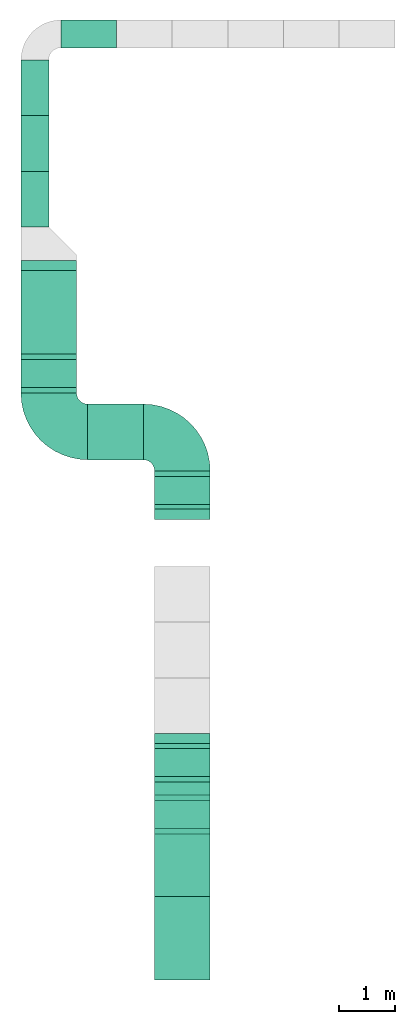
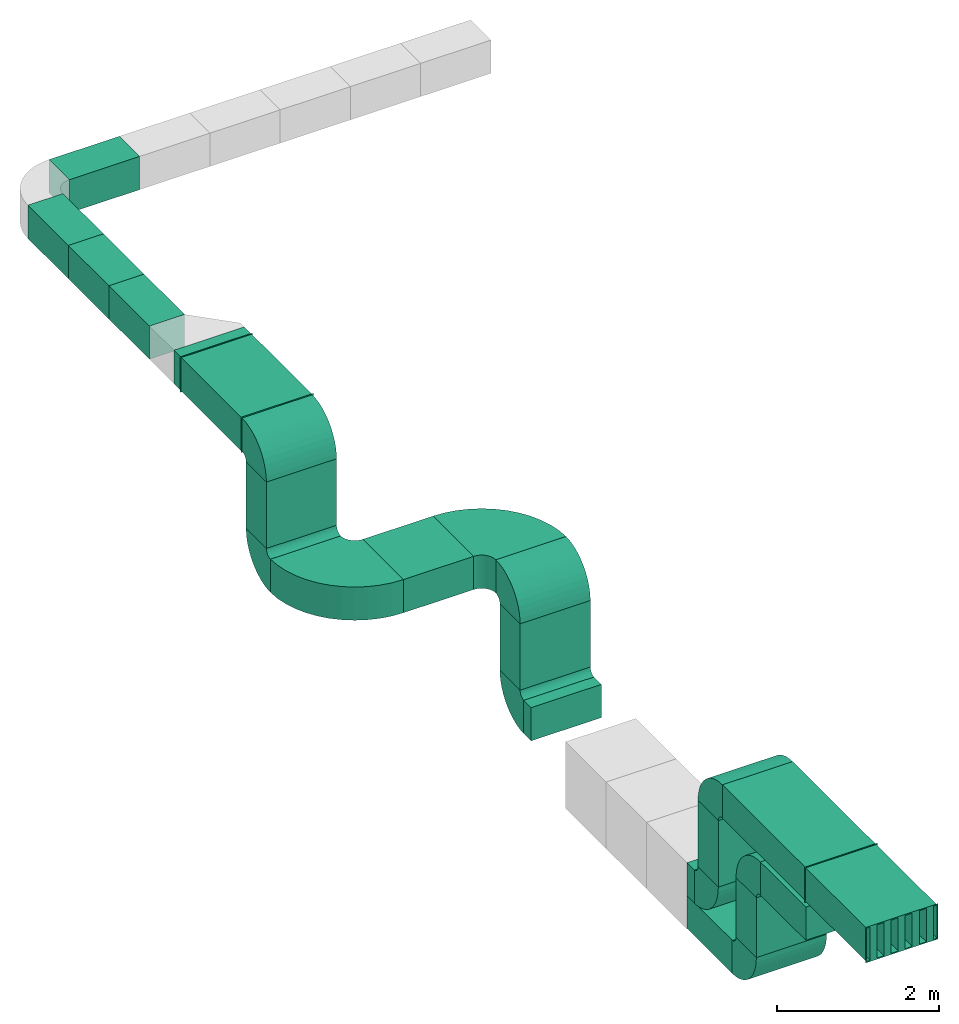
# One storey, part 1 of 3: 15 duct segments, 10 duct fittings, 2 duct silencers.
"""IFC4X3_ADD2 building model written with IfcOpenShell, lengths in millimetres."""

from ifc_helpers import new_model, entity, si_unit, converted_unit, frame, origin_with_axes, origin_2d_with_axis, place, context, subcontext, project, spatial, indexed_curve, rectangle, outline, extrude, polygons, source, transform, mapped, material, material_profile, profile_set, profile_usage, type_object, type_shapes, element, save


model = new_model("IFC4X3_ADD2")

# Units and contexts
model_context = context("Model", 3, precision=1e-05, world=origin_with_axes())
plan_context = context("Plan", 2, precision=1e-05, world=origin_2d_with_axis())
body_context = subcontext(model_context, "Body", "Model", "MODEL_VIEW")
ifc_project = project(units=[si_unit("VOLUMEUNIT", "CUBIC_METRE"), si_unit("LENGTHUNIT", "METRE", prefix="MILLI"), converted_unit("PLANEANGLEUNIT", "degree", entity("IfcReal", 0.0174532925199433), si_unit("PLANEANGLEUNIT", "RADIAN"), dimensions=[0, 0, 0, 0, 0, 0, 0]), si_unit("AREAUNIT", "SQUARE_METRE")], contexts=[model_context, plan_context])

# Site, building, storey
site_placement = place(None, origin_with_axes())
site = spatial("IfcSite", under=ifc_project, at=site_placement)
building_placement = place(site_placement, origin_with_axes())
building = spatial("IfcBuilding", under=site, at=building_placement, Name="Building")
storey_placement = place(building_placement, origin_with_axes())
storey = spatial("IfcBuildingStorey", under=building, at=storey_placement, Name="Storey")

# Duct silencers
duct_silencer_type = type_object("IfcDuctSilencerType", Name="Duct", PredefinedType="RECTANGULAR")
shared_shape_1 = source(origin_with_axes(), body_context, "Body", "Tessellation", [
    polygons([(350.0, -750.0, -249.999984741211), (450.000030517578, -750.0, -249.999984741211), (350.0, 750.0, -249.999984741211), (450.000030517578, 750.0, -249.999984741211), (350.0, -750.0, 249.999984741211), (450.000030517578, -750.0, 249.999984741211), (350.0, 750.0, 249.999984741211), (450.000030517578, 750.0, 249.999984741211), (150.000015258789, -750.0, -249.999984741211), (250.000015258789, -750.0, -249.999984741211), (150.000015258789, 750.0, -249.999984741211), (250.000015258789, 750.0, -249.999984741211), (150.000015258789, -750.0, 249.999984741211), (250.000015258789, -750.0, 249.999984741211), (150.000015258789, 750.0, 249.999984741211), (250.000015258789, 750.0, 249.999984741211), (-50.0, -750.0, -249.999984741211), (50.0, -750.0, -249.999984741211), (-50.0, 750.0, -249.999984741211), (50.0, 750.0, -249.999984741211), (-50.0, -750.0, 249.999984741211), (50.0, -750.0, 249.999984741211), (-50.0, 750.0, 249.999984741211), (50.0, 750.0, 249.999984741211), (-249.999969482422, -750.0, -249.999984741211), (-149.999984741211, -750.0, -249.999984741211), (-249.999969482422, 750.0, -249.999984741211), (-149.999984741211, 750.0, -249.999984741211), (-249.999969482422, -750.0, 249.999984741211), (-149.999984741211, -750.0, 249.999984741211), (-249.999969482422, 750.0, 249.999984741211), (-149.999984741211, 750.0, 249.999984741211), (-449.999969482422, -750.0, -249.999984741211), (-349.999938964844, -750.0, -249.999984741211), (-449.999969482422, 750.0, -249.999984741211), (-349.999938964844, 750.0, -249.999984741211), (-449.999969482422, -750.0, 249.999984741211), (-349.999938964844, -750.0, 249.999984741211), (-449.999969482422, 750.0, 249.999984741211), (-349.999938964844, 750.0, 249.999984741211), (-501.999938964844, -750.0, -251.999984741211), (-499.999969482422, -750.0, -249.999984741211), (-499.999969482422, -750.0, 0.0), (-499.999969482422, -750.0, 249.999984741211), (-501.999938964844, -750.0, 251.999984741211), (-499.999969482422, 0.0, -249.999984741211), (-501.999938964844, 750.0, -251.999984741211), (-499.999969482422, 750.0, -249.999984741211), (-499.999969482422, 0.0, 0.0), (-499.999969482422, 0.0, 249.999984741211), (-499.999969482422, 750.0, 0.0), (-499.999969482422, 750.0, 249.999984741211), (-501.999938964844, 750.0, 251.999984741211), (501.999938964844, -750.0, -251.999984741211), (499.999969482422, -750.0, -249.999984741211), (499.999969482422, -750.0, 0.0), (499.999969482422, -750.0, 249.999984741211), (501.999938964844, -750.0, 251.999984741211), (499.999969482422, 0.0, -249.999984741211), (501.999938964844, 750.0, -251.999984741211), (499.999969482422, 750.0, -249.999984741211), (499.999969482422, 0.0, 0.0), (499.999969482422, 0.0, 249.999984741211), (499.999969482422, 750.0, 0.0), (499.999969482422, 750.0, 249.999984741211), (501.999938964844, 750.0, 251.999984741211), (-516.999938964844, -750.0, -266.999969482422), (516.999938964844, -750.0, -266.999969482422), (-516.999938964844, -748.000061035156, -266.999969482422), (516.999938964844, -748.000061035156, -266.999969482422), (-516.999938964844, -750.0, 266.999969482422), (516.999938964844, -750.0, 266.999969482422), (-516.999938964844, -748.000061035156, 266.999969482422), (516.999938964844, -748.000061035156, 266.999969482422), (-501.999938964844, -749.999938964844, 251.999969482422), (-501.999938964844, -748.000122070312, 251.999984741211), (501.999938964844, -750.000061035156, 251.999984741211), (501.999938964844, -748.000122070312, 251.999984741211), (501.999938964844, -750.000061035156, -251.999984741211), (501.999938964844, -748.000122070312, -251.999984741211), (-501.999938964844, -749.999938964844, -251.999969482422), (-501.999938964844, -748.000122070312, -251.999984741211), (-516.999938964844, 748.000061035156, -266.999969482422), (516.999938964844, 748.000061035156, -266.999969482422), (-516.999938964844, 750.0, -266.999969482422), (516.999938964844, 750.0, -266.999969482422), (-516.999938964844, 748.000061035156, 266.999969482422), (516.999938964844, 748.000061035156, 266.999969482422), (-516.999938964844, 750.0, 266.999969482422), (516.999938964844, 750.0, 266.999969482422), (-501.999938964844, 748.000122070312, 251.999969482422), (-501.999938964844, 749.999938964844, 251.999984741211), (501.999938964844, 748.0, 251.999984741211), (501.999938964844, 749.999938964844, 251.999984741211), (501.999938964844, 748.0, -251.999984741211), (501.999938964844, 749.999938964844, -251.999984741211), (-501.999938964844, 748.000122070312, -251.999969482422), (-501.999938964844, 749.999938964844, -251.999984741211)], [[[1, 3, 4, 2]], [[1, 2, 6, 5]], [[5, 6, 8, 7]], [[3, 7, 8, 4]], [[1, 5, 7, 3]], [[2, 4, 8, 6]], [[9, 11, 12, 10]], [[9, 10, 14, 13]], [[13, 14, 16, 15]], [[11, 15, 16, 12]], [[9, 13, 15, 11]], [[10, 12, 16, 14]], [[17, 19, 20, 18]], [[17, 18, 22, 21]], [[21, 22, 24, 23]], [[19, 23, 24, 20]], [[17, 21, 23, 19]], [[18, 20, 24, 22]], [[25, 27, 28, 26]], [[25, 26, 30, 29]], [[29, 30, 32, 31]], [[27, 31, 32, 28]], [[25, 29, 31, 27]], [[26, 28, 32, 30]], [[33, 35, 36, 34]], [[33, 34, 38, 37]], [[37, 38, 40, 39]], [[35, 39, 40, 36]], [[33, 37, 39, 35]], [[34, 36, 40, 38]], [[41, 47, 60, 54]], [[45, 41, 43]], [[54, 58, 57, 56]], [[66, 53, 45, 58]], [[51, 48, 61, 64, 60, 47, 53, 66, 65, 52]], [[60, 64, 65, 66]], [[41, 45, 53, 47]], [[66, 58, 54, 60]], [[59, 46, 42, 55]], [[61, 48, 46, 59]], [[44, 50, 63, 57]], [[50, 52, 65, 63]], [[49, 43, 42, 46]], [[51, 49, 46, 48]], [[50, 44, 43, 49]], [[52, 50, 49, 51]], [[55, 56, 62, 59]], [[59, 62, 64, 61]], [[56, 57, 63, 62]], [[62, 63, 65, 64]], [[67, 69, 70, 68]], [[75, 72, 71]], [[71, 72, 74, 73]], [[69, 82, 70]], [[67, 71, 73, 69]], [[68, 70, 74, 72]], [[79, 67, 68]], [[77, 78, 80, 79]], [[79, 80, 82, 81]], [[75, 76, 78, 77]], [[81, 82, 76, 75]], [[78, 73, 74]], [[83, 85, 86, 84]], [[91, 88, 87]], [[87, 88, 90, 89]], [[85, 98, 86]], [[83, 87, 89, 85]], [[84, 86, 90, 88]], [[95, 83, 84]], [[93, 94, 96, 95]], [[95, 96, 98, 97]], [[91, 92, 94, 93]], [[97, 98, 92, 91]], [[94, 89, 90]], [[54, 56, 55]], [[54, 55, 42]], [[57, 58, 45]], [[44, 57, 45]], [[41, 54, 42]], [[43, 44, 45]], [[41, 42, 43]], [[71, 67, 81]], [[75, 77, 72]], [[71, 81, 75]], [[69, 73, 76]], [[82, 80, 70]], [[69, 76, 82]], [[68, 72, 77]], [[79, 81, 67]], [[68, 77, 79]], [[74, 70, 80]], [[78, 76, 73]], [[74, 80, 78]], [[87, 83, 97]], [[91, 93, 88]], [[87, 97, 91]], [[85, 89, 92]], [[98, 96, 86]], [[85, 92, 98]], [[84, 88, 93]], [[95, 97, 83]], [[84, 93, 95]], [[90, 86, 96]], [[94, 92, 89]], [[90, 96, 94]]], closed=True),
])
type_shapes(duct_silencer_type, [shared_shape_1])
for number, where, z_axis, x_axis in (
    (1, (-133.152961730957, 957.489967346191, 4035.20965576172), (0.0, 0.0, 1.0), (1.0, 0.0, 0.0)),
    (2, (2264.84680175781, -10289.3934249878, 2335.26062965393), (0.0, 0.0, 1.0), (1.0, 0.0, 0.0)),
):
    element("IfcDuctSilencer", number, at=place(storey_placement, frame(where, z_axis=z_axis, x_axis=x_axis)), inside=storey, type_object=duct_silencer_type, context=body_context, shape_type="MappedRepresentation", body=[
        mapped(shared_shape_1, transform((0.0, 0.0, 0.0), x_axis=(1.0, 0.0, 0.0), y_axis=(0.0, 1.0, 0.0), z_axis=(0.0, 0.0, 1.0), scale=1.0)),
    ])

# Duct segments
ifc_material = material()
ifc_material_profile_1 = material_profile(ifc_material, outline(indexed_curve([(-249.999954223633, 249.999954223633), (249.999954223633, 249.999954223633), (249.999954223633, -249.999954223633), (-249.999954223633, -249.999954223633), (-249.999954223633, 249.999954223633)])))
ifc_profile_set_1 = profile_set([ifc_material_profile_1])
ifc_profile_usage_1 = profile_usage(ifc_profile_set_1, cardinal=5)
duct_segment_type_1 = type_object("IfcDuctSegmentType", Name="Duct500x500", PredefinedType="RIGIDSEGMENT", material=ifc_profile_set_1)
duct_segment_1_placement = place(storey_placement, frame((-383.152931928635, 2490.50331115723, 4035.20965576172), z_axis=(-8.74227765734753e-08, 0.999999999999993, 7.54979012640428e-08), x_axis=(-0.999999999999992, -8.74227765734752e-08, 8.74227836789026e-08)))
element("IfcDuctSegment", 3, at=duct_segment_1_placement, inside=storey, type_object=duct_segment_type_1, material=ifc_profile_usage_1, Name="DuctSegment", context=body_context, shape_type="SweptSolid", body=[
    extrude(outline(indexed_curve([(-249.999954223633, 249.999954223633), (249.999954223633, 249.999954223633), (249.999954223633, -249.999954223633), (-249.999954223633, -249.999954223633), (-249.999954223633, 249.999954223633)])), origin_with_axes(), (0.0, 0.0, 1.0), 1000.00000000001),
])
ifc_profile_usage_2 = profile_usage(ifc_profile_set_1, cardinal=5)
duct_segment_2_placement = place(storey_placement, frame((1084.83171463013, 5958.48846435547, 4035.2087020874), z_axis=(-0.999999999999997, -1.19248735330757e-08, 7.54979012640431e-08), x_axis=(1.1924880638503e-08, -0.999999999999996, 8.74227765734755e-08)))
element("IfcDuctSegment", 4, at=duct_segment_2_placement, inside=storey, type_object=duct_segment_type_1, material=ifc_profile_usage_2, Name="DuctSegment", context=body_context, shape_type="SweptSolid", body=[
    extrude(outline(indexed_curve([(-249.999954223633, 249.999954223633), (249.999954223633, 249.999954223633), (249.999954223633, -249.999954223633), (-249.999954223633, -249.999954223633), (-249.999954223633, 249.999954223633)])), origin_with_axes(), (0.0, 0.0, 1.0), 1000.00000000001),
])
ifc_profile_usage_3 = profile_usage(ifc_profile_set_1, cardinal=5)
duct_segment_3_placement = place(storey_placement, frame((-383.152931928635, 3490.50331115723, 4035.20965576172), z_axis=(-8.74227765734753e-08, 0.999999999999993, 7.54979012640428e-08), x_axis=(-0.999999999999992, -8.74227765734752e-08, 8.74227836789026e-08)))
element("IfcDuctSegment", 5, at=duct_segment_3_placement, inside=storey, type_object=duct_segment_type_1, material=ifc_profile_usage_3, Name="DuctSegment", context=body_context, shape_type="SweptSolid", body=[
    extrude(outline(indexed_curve([(-249.999954223633, 249.999954223633), (249.999954223633, 249.999954223633), (249.999954223633, -249.999954223633), (-249.999954223633, -249.999954223633), (-249.999954223633, 249.999954223633)])), origin_with_axes(), (0.0, 0.0, 1.0), 1000.00000000001),
])
ifc_profile_usage_4 = profile_usage(ifc_profile_set_1, cardinal=5)
duct_segment_4_placement = place(storey_placement, frame((-383.152931928635, 4490.50331115723, 4035.20965576172), z_axis=(-8.74227765734753e-08, 0.999999999999993, 7.54979012640428e-08), x_axis=(-0.999999999999992, -8.74227765734752e-08, 8.74227836789026e-08)))
element("IfcDuctSegment", 6, at=duct_segment_4_placement, inside=storey, type_object=duct_segment_type_1, material=ifc_profile_usage_4, Name="DuctSegment", context=body_context, shape_type="SweptSolid", body=[
    extrude(outline(indexed_curve([(-249.999954223633, 249.999954223633), (249.999954223633, 249.999954223633), (249.999954223633, -249.999954223633), (-249.999954223633, -249.999954223633), (-249.999954223633, 249.999954223633)])), origin_with_axes(), (0.0, 0.0, 1.0), 1000.00000000001),
])
ifc_material_profile_2 = material_profile(ifc_material, rectangle(XDim=1000.0, YDim=500.0))
ifc_profile_set_2 = profile_set([ifc_material_profile_2], Name="duct1000x500")
ifc_profile_usage_5 = profile_usage(ifc_profile_set_2, cardinal=5)
duct_segment_type_2 = type_object("IfcDuctSegmentType", Name="Duct1000x500", PredefinedType="RIGIDSEGMENT", material=ifc_profile_set_2)
duct_segment_5_placement = place(storey_placement, frame((-133.152961730957, 1707.48996734619, 4035.20965576172), z_axis=(-8.74227765734753e-08, 0.999999999999993, 7.54979012640428e-08), x_axis=(-0.999999999999992, -8.74227765734752e-08, 8.74227836789026e-08)))
element("IfcDuctSegment", 7, at=duct_segment_5_placement, inside=storey, type_object=duct_segment_type_2, material=ifc_profile_usage_5, Name="DuctSegment", context=body_context, shape_type="SweptSolid", body=[
    extrude(rectangle(XDim=1000.0, YDim=500.0), origin_with_axes(), (0.0, 0.0, 1.0), 183.01284481853),
])
ifc_profile_usage_6 = profile_usage(ifc_profile_set_2, cardinal=5)
duct_segment_6_placement = place(storey_placement, frame((-133.153080940247, -142.484813928604, 3685.23502349854), z_axis=(-1.50995816738939e-07, -8.74227623626198e-08, -0.999999999999985), x_axis=(-0.999999999999978, 1.47027421348863e-07, 1.50995802528083e-07)))
element("IfcDuctSegment", 8, at=duct_segment_6_placement, inside=storey, type_object=duct_segment_type_2, material=ifc_profile_usage_6, Name="DuctSegment", context=body_context, shape_type="SweptSolid", body=[
    extrude(rectangle(XDim=1000.0, YDim=500.0), origin_with_axes(), (0.0, 0.0, 1.0), 1000.0),
])
ifc_profile_usage_7 = profile_usage(ifc_profile_set_2, cardinal=5)
duct_segment_7_placement = place(storey_placement, frame((566.84684753418, -1192.45946407318, 2335.26062965393), z_axis=(0.999999999999962, -1.94707169498535e-07, 1.9470718370939e-07), x_axis=(1.94707183709392e-07, 0.999999999999974, -1.19209289550778e-07)))
element("IfcDuctSegment", 9, at=duct_segment_7_placement, inside=storey, type_object=duct_segment_type_2, material=ifc_profile_usage_7, Name="DuctSegment", context=body_context, shape_type="SweptSolid", body=[
    extrude(rectangle(XDim=1000.0, YDim=500.0), origin_with_axes(), (0.0, 0.0, 1.0), 1000.0),
])
ifc_profile_usage_8 = profile_usage(ifc_profile_set_2, cardinal=5)
duct_segment_8_placement = place(storey_placement, frame((2266.84665679932, -2242.43450164795, 1985.28599739075), z_axis=(-1.50995816738939e-07, -8.74227623626198e-08, -0.999999999999985), x_axis=(-0.999999999999978, 1.47027421348863e-07, 1.50995802528083e-07)))
element("IfcDuctSegment", 10, at=duct_segment_8_placement, inside=storey, type_object=duct_segment_type_2, material=ifc_profile_usage_8, Name="DuctSegment", context=body_context, shape_type="SweptSolid", body=[
    extrude(rectangle(XDim=1000.0, YDim=500.0), origin_with_axes(), (0.0, 0.0, 1.0), 1000.0),
])
ifc_profile_usage_9 = profile_usage(ifc_profile_set_2, cardinal=5)
duct_segment_9_placement = place(storey_placement, frame((2266.84665679932, -2762.37297058105, 636.166334152222), z_axis=(-8.74227765734753e-08, 0.999999999999993, 7.54979012640428e-08), x_axis=(-0.999999999999992, -8.74227765734752e-08, 8.74227836789026e-08)))
element("IfcDuctSegment", 11, at=duct_segment_9_placement, inside=storey, type_object=duct_segment_type_2, material=ifc_profile_usage_9, Name="DuctSegment", context=body_context, shape_type="SweptSolid", body=[
    extrude(rectangle(XDim=1000.0, YDim=500.0), origin_with_axes(), (0.0, 0.0, 1.0), 183.01284481853),
])
ifc_profile_usage_10 = profile_usage(ifc_profile_set_2, cardinal=5)
duct_segment_10_placement = place(storey_placement, frame((2266.8468952179, -7129.34398651123, 1985.28575897217), z_axis=(1.50995816738939e-07, 8.74227623626198e-08, -0.999999999999985), x_axis=(0.999999999999977, -1.50995802528083e-07, 1.50995802528083e-07)))
element("IfcDuctSegment", 12, at=duct_segment_10_placement, inside=storey, type_object=duct_segment_type_2, material=ifc_profile_usage_10, Name="DuctSegment", context=body_context, shape_type="SweptSolid", body=[
    extrude(rectangle(XDim=1000.0, YDim=500.0), origin_with_axes(), (0.0, 0.0, 1.0), 1000.0),
])
ifc_profile_usage_11 = profile_usage(ifc_profile_set_2, cardinal=5)
duct_segment_11_placement = place(storey_placement, frame((2266.8468952179, -6609.40551757812, 636.166274547577), z_axis=(1.74845553146949e-07, -0.999999999999982, 7.54979012640419e-08), x_axis=(0.999999999999981, 1.74845553146948e-07, 8.74227836789015e-08)))
element("IfcDuctSegment", 13, at=duct_segment_11_placement, inside=storey, type_object=duct_segment_type_2, material=ifc_profile_usage_11, Name="DuctSegment", context=body_context, shape_type="SweptSolid", body=[
    extrude(rectangle(XDim=1000.0, YDim=500.0), origin_with_axes(), (0.0, 0.0, 1.0), 183.01284481853),
])
ifc_profile_usage_12 = profile_usage(ifc_profile_set_2, cardinal=5)
duct_segment_12_placement = place(storey_placement, frame((2266.8468952179, -8067.87490844727, 1394.05369758606), z_axis=(1.50995816738939e-07, 8.74227623626198e-08, -0.999999999999985), x_axis=(0.999999999999977, -1.50995802528083e-07, 1.50995802528083e-07)))
element("IfcDuctSegment", 14, at=duct_segment_12_placement, inside=storey, type_object=duct_segment_type_2, material=ifc_profile_usage_12, Name="DuctSegment", context=body_context, shape_type="SweptSolid", body=[
    extrude(rectangle(XDim=1000.0, YDim=500.0), origin_with_axes(), (0.0, 0.0, 1.0), 899.99986886978),
])
ifc_profile_usage_13 = profile_usage(ifc_profile_set_2, cardinal=5)
duct_segment_13_placement = place(storey_placement, frame((2266.8468952179, -6609.40551757812, 144.934475421906), z_axis=(1.74845553146949e-07, -0.999999999999982, 7.54979012640419e-08), x_axis=(0.999999999999981, 1.74845553146948e-07, 8.74227836789015e-08)))
element("IfcDuctSegment", 15, at=duct_segment_13_placement, inside=storey, type_object=duct_segment_type_2, material=ifc_profile_usage_13, Name="DuctSegment", context=body_context, shape_type="SweptSolid", body=[
    extrude(rectangle(XDim=1000.0, YDim=500.0), origin_with_axes(), (0.0, 0.0, 1.0), 1121.54387366388),
])
ifc_profile_usage_14 = profile_usage(ifc_profile_set_2, cardinal=5)
duct_segment_14_placement = place(storey_placement, frame((2266.84665679932, -8417.84954071045, 1744.02856826782), z_axis=(1.74845553146949e-07, -0.999999999999982, 7.54979012640419e-08), x_axis=(0.999999999999981, 1.74845553146948e-07, 8.74227836789015e-08)))
element("IfcDuctSegment", 16, at=duct_segment_14_placement, inside=storey, type_object=duct_segment_type_2, material=ifc_profile_usage_14, Name="DuctSegment", context=body_context, shape_type="SweptSolid", body=[
    extrude(rectangle(XDim=1000.0, YDim=500.0), origin_with_axes(), (0.0, 0.0, 1.0), 1121.54387366388),
])
ifc_profile_usage_15 = profile_usage(ifc_profile_set_2, cardinal=5)
duct_segment_15_placement = place(storey_placement, frame((2266.84665679932, -7479.31861877441, 2335.26039123535), z_axis=(1.74845553146949e-07, -0.999999999999982, 7.54979012640419e-08), x_axis=(0.999999999999981, 1.74845553146948e-07, 8.74227836789015e-08)))
element("IfcDuctSegment", 17, at=duct_segment_15_placement, inside=storey, type_object=duct_segment_type_2, material=ifc_profile_usage_15, Name="DuctSegment", context=body_context, shape_type="SweptSolid", body=[
    extrude(rectangle(XDim=1000.0, YDim=500.0), origin_with_axes(), (0.0, 0.0, 1.0), 2060.07485429636),
])

# Duct fittings
duct_fitting_type_1 = type_object("IfcDuctFittingType", Name="Duct 1000x500 Bend", PredefinedType="BEND")
shared_shape_2 = source(origin_with_axes(), body_context, "Body", "Tessellation", [
    polygons([(-499.999969482422, -249.999984741211, 0.0), (499.999969482422, -249.999984741211, 0.0), (-499.999969482422, 249.999984741211, 0.0), (499.999969482422, 249.999984741211, 0.0), (-499.999969482422, -244.867126464844, -78.3124160766602), (499.999969482422, -244.867126464844, -78.3124084472656), (-499.999969482422, 250.855285644531, -13.0493183135986), (499.999969482422, 250.855285644531, -13.0493106842041), (-499.999969482422, -229.556365966797, -155.284881591797), (499.999969482422, -229.556365966797, -155.284866333008), (-499.999969482422, 253.40657043457, -25.875358581543), (499.999969482422, 253.406539916992, -25.8753433227539), (-499.999969482422, -204.329650878906, -229.600402832031), (499.999969482422, -204.329650878906, -229.600372314453), (-499.999969482422, 257.610168457031, -38.2586631774902), (499.999969482422, 257.610137939453, -38.2586479187012), (-499.999969482422, -169.618621826172, -299.987426757812), (499.999969482422, -169.618621826172, -299.987365722656), (-499.999969482422, 263.394134521484, -49.9873466491699), (499.999969482422, 263.394104003906, -49.9873275756836), (-499.999969482422, -126.017204284668, -365.241516113281), (499.999969482422, -126.017234802246, -365.241455078125), (-499.999969482422, 270.659515380859, -60.8607292175293), (499.999969482422, 270.659484863281, -60.860710144043), (-499.999969482422, -74.2714462280273, -424.246215820312), (499.999969482422, -74.271484375, -424.246154785156), (-499.999969482422, 279.282012939453, -70.6927719116211), (499.999969482422, 279.281982421875, -70.692741394043), (-499.999969482422, -15.2667121887207, -475.992004394531), (499.999969482422, -15.2667636871338, -475.991943359375), (-499.999969482422, 289.114074707031, -79.3152313232422), (499.999969482422, 289.114044189453, -79.3151931762695), (-499.999969482422, 49.9874076843262, -519.593383789062), (499.999969482422, 49.9873466491699, -519.593322753906), (-499.999969482422, 299.987487792969, -86.5805816650391), (499.999969482422, 299.987426757812, -86.5805358886719), (-499.999969482422, 120.374397277832, -554.304382324219), (499.999969482422, 120.374320983887, -554.304321289062), (-499.999969482422, 311.716186523438, -92.3645172119141), (499.999969482422, 311.716125488281, -92.3644714355469), (-499.999969482422, 194.689910888672, -579.531127929688), (499.999969482422, 194.689834594727, -579.531066894531), (-499.999969482422, 324.099487304688, -96.5680618286133), (499.999969482422, 324.099426269531, -96.5680236816406), (-499.999969482422, 271.662384033203, -594.841857910156), (499.999969482422, 271.662322998047, -594.841796875), (-499.999969482422, 336.925506591797, -99.1193084716797), (499.999969482422, 336.925445556641, -99.119270324707), (-499.999969482422, 349.974822998047, -599.974792480469), (499.999969482422, 349.974731445312, -599.974731445312), (-499.999969482422, 349.974822998047, -99.9745788574219), (499.999969482422, 349.974761962891, -99.9745483398438)], [[[1, 3, 4, 2]], [[6, 8, 12, 10]], [[1, 2, 6, 5]], [[2, 4, 8, 6]], [[3, 1, 5, 7]], [[4, 3, 7, 8]], [[11, 9, 13, 15]], [[7, 5, 9, 11]], [[8, 7, 11, 12]], [[5, 6, 10, 9]], [[16, 15, 19, 20]], [[12, 11, 15, 16]], [[9, 10, 14, 13]], [[10, 12, 16, 14]], [[18, 20, 24, 22]], [[13, 14, 18, 17]], [[14, 16, 20, 18]], [[15, 13, 17, 19]], [[24, 23, 27, 28]], [[19, 17, 21, 23]], [[20, 19, 23, 24]], [[17, 18, 22, 21]], [[25, 26, 30, 29]], [[21, 22, 26, 25]], [[22, 24, 28, 26]], [[23, 21, 25, 27]], [[30, 32, 36, 34]], [[26, 28, 32, 30]], [[27, 25, 29, 31]], [[28, 27, 31, 32]], [[36, 35, 39, 40]], [[31, 29, 33, 35]], [[32, 31, 35, 36]], [[29, 30, 34, 33]], [[38, 40, 44, 42]], [[33, 34, 38, 37]], [[34, 36, 40, 38]], [[35, 33, 37, 39]], [[42, 44, 48, 46]], [[39, 37, 41, 43]], [[40, 39, 43, 44]], [[37, 38, 42, 41]], [[48, 47, 51, 52]], [[43, 41, 45, 47]], [[44, 43, 47, 48]], [[41, 42, 46, 45]], [[49, 50, 52, 51]], [[45, 46, 50, 49]], [[46, 48, 52, 50]], [[47, 45, 49, 51]]]),
])
type_shapes(duct_fitting_type_1, [shared_shape_2])
for number, where, z_axis, x_axis, name in (
    (18, (-133.153080940247, -142.484813928604, 3685.23502349854), (-3.25841369885876e-07, 0.0, -0.999999999999947), (-0.999999999999947, 0.0, 3.25841369885876e-07), "DuctFitting"),
    (19, (-133.153080940247, -142.484813928604, 2685.23502349854), (-3.89414367418744e-07, -3.25841369885851e-07, 0.999999999999871), (-0.999999999999924, 2.8485958573517e-14, -3.89414367418765e-07), "DuctFitting"),
    (20, (2266.84665679932, -2242.43450164795, 1985.28599739075), (-3.25841369885876e-07, 0.0, -0.999999999999947), (-0.999999999999947, 0.0, 3.25841369885876e-07), "DuctFitting"),
    (21, (2266.84665679932, -2242.43450164795, 985.285997390747), (-3.89414367418744e-07, -3.25841369885851e-07, 0.999999999999871), (-0.999999999999924, 2.8485958573517e-14, -3.89414367418765e-07), "DuctFitting"),
    (22, (2266.8468952179, -7129.34398651123, 1985.28575897217), (5.64259948987366e-07, 1.83859221250497e-13, -0.999999999999841), (0.999999999999788, 3.25841369885824e-07, 5.64259948987336e-07), "DuctFitting"),
    (23, (2266.8468952179, -7129.34398651123, 985.285937786102), (3.89414196888446e-07, 5.64260062674161e-07, 0.999999999999765), (0.999999999999871, 3.25841369885851e-07, -3.89414367418744e-07), "DuctFitting"),
    (24, (2266.8468952179, -8067.87490844727, 1394.05393600464), (5.64259948987366e-07, 1.83859221250497e-13, -0.999999999999841), (0.999999999999788, 3.25841369885824e-07, 5.64259948987336e-07), "DuctFitting"),
    (25, (2266.84713363647, -8067.87490844727, 494.053781032562), (0.0, 0.0, 1.0), (1.0, 0.0, 0.0), "DuctFitting"),
):
    element("IfcDuctFitting", number, at=place(storey_placement, frame(where, z_axis=z_axis, x_axis=x_axis)), inside=storey, type_object=duct_fitting_type_1, Name=name, context=body_context, shape_type="MappedRepresentation", body=[
        mapped(shared_shape_2, transform((0.0, 0.0, 0.0), x_axis=(1.0, 0.0, 0.0), y_axis=(0.0, 1.0, 0.0), z_axis=(0.0, 0.0, 1.0), scale=1.0)),
    ])
duct_fitting_type_2 = type_object("IfcDuctFittingType", Name="Duct 1000x500 bend 90", PredefinedType="BEND")
shared_shape_3 = source(origin_with_axes(), body_context, "Body", "Tessellation", [
    polygons([(-249.999984741211, -499.999969482422, 0.0), (249.999984741211, -499.999969482422, 0.0), (-249.999984741211, 499.999969482422, 0.0), (249.999984741211, 499.999969482422, 0.0), (-249.999984741211, -501.710968017578, 26.1052169799805), (249.999984741211, -501.710968017578, 26.1052169799805), (-249.999984741211, 489.733856201172, 156.631393432617), (249.999984741211, 489.733856201172, 156.631393432617), (-249.999984741211, -506.814819335938, 51.7637710571289), (249.999984741211, -506.814819335938, 51.7637710571289), (-249.999984741211, 459.110992431641, 310.582794189453), (249.999984741211, 459.110992431641, 310.582794189453), (-249.999984741211, -515.224060058594, 76.53662109375), (249.999984741211, -515.224060058594, 76.53662109375), (-249.999984741211, 408.655487060547, 459.220062255859), (249.999984741211, 408.655487060547, 459.220031738281), (-249.999984741211, -526.794860839844, 99.9999160766602), (249.999984741211, -526.794860839844, 99.9999160766602), (-249.999984741211, 339.230590820312, 599.999938964844), (249.999984741211, 339.230590820312, 599.999877929688), (-249.999984741211, -541.329284667969, 121.752182006836), (249.999984741211, -541.329284667969, 121.752182006836), (-249.999984741211, 252.024154663086, 730.513671875), (249.999984741211, 252.024154663086, 730.513610839844), (-249.999984741211, -558.578552246094, 141.42121887207), (249.999984741211, -558.578552246094, 141.42121887207), (-249.999984741211, 148.5283203125, 848.528076171875), (249.999984741211, 148.5283203125, 848.528015136719), (-249.999984741211, -578.247680664062, 158.670516967773), (249.999984741211, -578.247680664062, 158.670516967773), (-249.999969482422, 30.5139026641846, 952.023986816406), (249.999984741211, 30.5139102935791, 952.02392578125), (-249.999984741211, -600.0, 173.204925537109), (249.999984741211, -600.0, 173.204925537109), (-249.999954223633, -99.9998092651367, 1039.23046875), (249.999984741211, -99.9997940063477, 1039.23034667969), (-249.999984741211, -623.463317871094, 184.775726318359), (249.999984741211, -623.463317871094, 184.775726318359), (-249.999938964844, -240.779693603516, 1108.65551757812), (249.999984741211, -240.779663085938, 1108.65539550781), (-249.999984741211, -648.236206054688, 193.184982299805), (249.999984741211, -648.236206054688, 193.184982299805), (-249.999923706055, -389.416961669922, 1159.11108398438), (249.999984741211, -389.416961669922, 1159.11096191406), (-249.999984741211, -673.894714355469, 198.288757324219), (249.999984741211, -673.894714355469, 198.288757324219), (-249.999908447266, -543.368408203125, 1189.73388671875), (249.999984741211, -543.368408203125, 1189.73376464844), (-249.999984741211, -699.999938964844, 199.999771118164), (249.999984741211, -699.999938964844, 199.999771118164), (-249.999893188477, -699.999877929688, 1200.00012207031), (249.999984741211, -699.999877929688, 1200.0)], [[[1, 3, 4, 2]], [[8, 7, 11, 12]], [[2, 4, 8, 6]], [[3, 1, 5, 7]], [[4, 3, 7, 8]], [[1, 2, 6, 5]], [[9, 10, 14, 13]], [[5, 6, 10, 9]], [[6, 8, 12, 10]], [[7, 5, 9, 11]], [[14, 16, 20, 18]], [[10, 12, 16, 14]], [[11, 9, 13, 15]], [[12, 11, 15, 16]], [[20, 19, 23, 24]], [[15, 13, 17, 19]], [[16, 15, 19, 20]], [[13, 14, 18, 17]], [[22, 24, 28, 26]], [[17, 18, 22, 21]], [[18, 20, 24, 22]], [[19, 17, 21, 23]], [[26, 28, 32, 30]], [[23, 21, 25, 27]], [[24, 23, 27, 28]], [[21, 22, 26, 25]], [[32, 31, 35, 36]], [[27, 25, 29, 31]], [[28, 27, 31, 32]], [[25, 26, 30, 29]], [[34, 36, 40, 38]], [[29, 30, 34, 33]], [[30, 32, 36, 34]], [[31, 29, 33, 35]], [[39, 37, 41, 43]], [[35, 33, 37, 39]], [[36, 35, 39, 40]], [[33, 34, 38, 37]], [[44, 43, 47, 48]], [[40, 39, 43, 44]], [[37, 38, 42, 41]], [[38, 40, 44, 42]], [[46, 48, 52, 50]], [[41, 42, 46, 45]], [[42, 44, 48, 46]], [[43, 41, 45, 47]], [[49, 50, 52, 51]], [[47, 45, 49, 51]], [[48, 47, 51, 52]], [[45, 46, 50, 49]]]),
])
type_shapes(duct_fitting_type_2, [shared_shape_3])
for number, where, z_axis, x_axis, name in (
    (26, (-133.153080940247, -492.459565401077, 2335.26062965393), (4.37113882867379e-08, -0.999999999999999, -5.21253117251541e-16), (1.19248806385031e-08, 0.0, 1.0), "DuctFitting"),
    (27, (2266.84665679932, -1892.45963096619, 2335.26039123535), (-1.19248806385031e-08, 1.0, 5.82842905137563e-15), (4.88762054828781e-07, 0.0, 0.999999999999881), "DuctFitting"),
):
    element("IfcDuctFitting", number, at=place(storey_placement, frame(where, z_axis=z_axis, x_axis=x_axis)), inside=storey, type_object=duct_fitting_type_2, Name=name, context=body_context, shape_type="MappedRepresentation", body=[
        mapped(shared_shape_3, transform((0.0, 0.0, 0.0), x_axis=(1.0, 0.0, 0.0), y_axis=(0.0, 1.0, 0.0), z_axis=(0.0, 0.0, 1.0), scale=1.0)),
    ])

save(model, "model.ifc")
